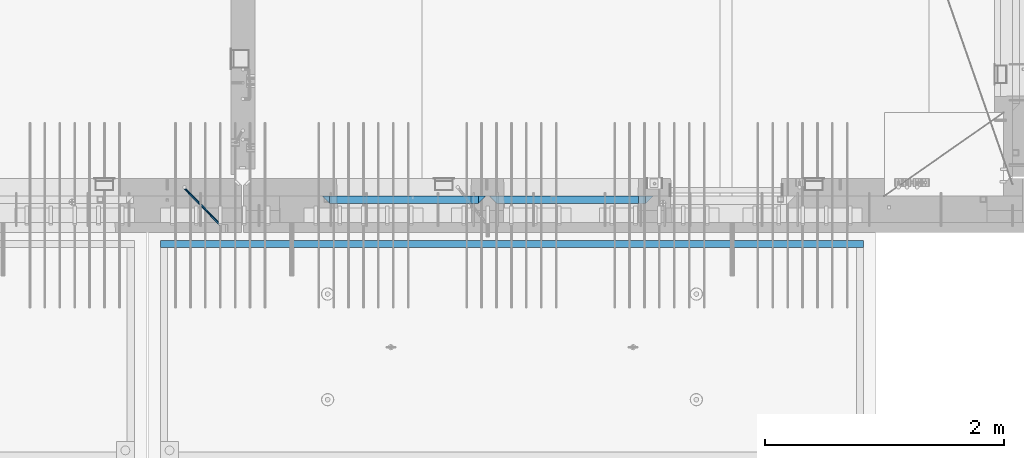
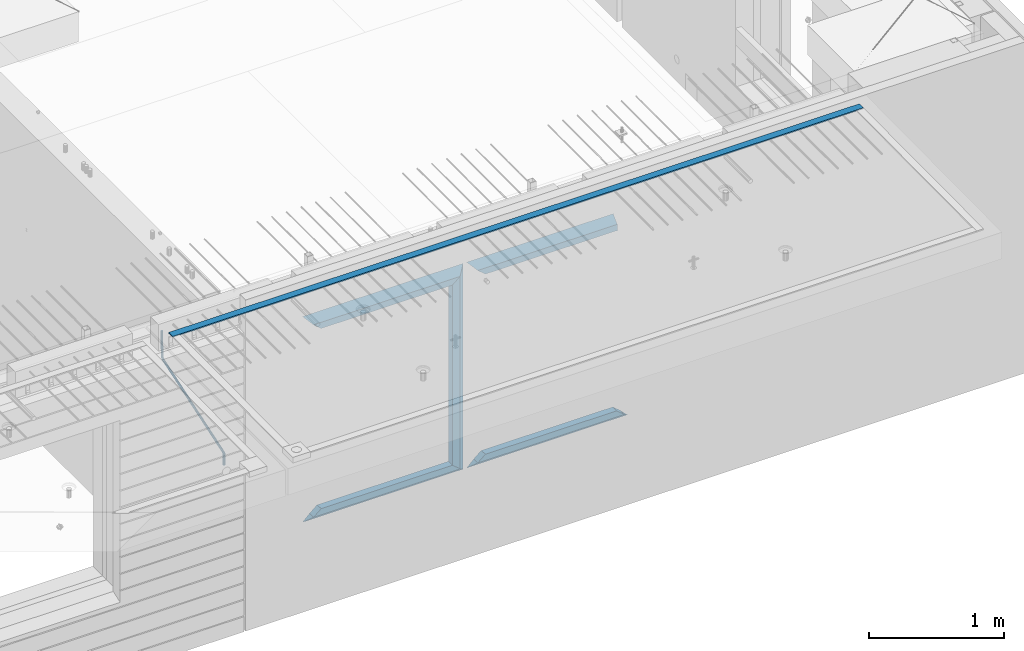
# One storey, part 98 of 350: 12 beams, 3 elements without a shape of their own.
"""IFC2X3 building model written with IfcOpenShell, lengths in millimetres."""

from ifc_helpers import new_model, si_unit, frame, origin_with_axes, place, context, subcontext, project, spatial, faceted_brep, material, type_object, element, aggregate, save


model = new_model("IFC2X3")

# Units and contexts
model_context = context("Model", 3, precision=1e-05, world=origin_with_axes())
body_context = subcontext(model_context, "Body", "Model", "MODEL_VIEW")
ifc_project = project(units=[si_unit("LENGTHUNIT", "METRE", prefix="MILLI"), si_unit("AREAUNIT", "SQUARE_METRE"), si_unit("VOLUMEUNIT", "CUBIC_METRE"), si_unit("MASSUNIT", "GRAM", prefix="KILO"), si_unit("TIMEUNIT", "SECOND"), si_unit("PLANEANGLEUNIT", "RADIAN"), si_unit("SOLIDANGLEUNIT", "STERADIAN"), si_unit("THERMODYNAMICTEMPERATUREUNIT", "DEGREE_CELSIUS"), si_unit("LUMINOUSINTENSITYUNIT", "LUMEN")], contexts=[model_context])

# Site, building, storey
site_placement = place(None, origin_with_axes())
site = spatial("IfcSite", under=ifc_project, at=site_placement, CompositionType="ELEMENT")
building_placement = place(site_placement, origin_with_axes())
building = spatial("IfcBuilding", under=site, at=building_placement, CompositionType="ELEMENT")
storey_placement = place(building_placement, origin_with_axes())
storey = spatial("IfcBuildingStorey", under=building, at=storey_placement, Name="2", CompositionType="ELEMENT", Elevation=0.0)

# Assembly, beam
assembly_1_placement = place(storey_placement, origin_with_axes())
assembly_1 = element("IfcElementAssembly", 1, at=assembly_1_placement, inside=storey, AssemblyPlace="NOTDEFINED", PredefinedType="REINFORCEMENT_UNIT")
ifc_material_1 = material()
beam_type_1 = type_object("IfcBeamType", Name="D20", PredefinedType="NOTDEFINED")
beam_1_placement = place(assembly_1_placement, frame((28120.0219996506, 7924.99999995055, 87407.5), z_axis=(-0.000415599999849952, -0.999999913638316, 0.0), x_axis=(-0.00018169900008877, 0.0, -0.999999983492737)))
beam_1 = element("IfcBeam", 2, at=beam_1_placement, type_object=beam_type_1, material=ifc_material_1, Name="JM20", ObjectType="D20", context=body_context, shape_type="Brep", body=[
    faceted_brep([(-0.00060564729210455, -9.99999998165731, 0.0), (-0.000428079845733009, -7.07106779890455, -7.07106781186667), (119.575515501536, -7.07830994756296, -7.07106481604933), (119.575337932896, -10.0072421307195, -3.43332612828817e-06), (0.0, 0.0, -10.0), (119.575943836026, -0.00724214867295814, -9.99999700418266), (0.00042843479604926, 7.07106779888636, -7.07106781186303), (119.57637202373, 7.06382565022977, -7.07106481604933), (0.00060564729210455, 9.99999998166459, 3.63797880709171e-12), (119.576549238118, 9.99275783300072, 2.99581552098971e-06), (0.000428079845733009, 7.07106779890819, 7.07106781186667), (119.576371669405, 7.06382565024978, 7.07107080768037), (0.0, 0.0, 10.0), (119.57594333493, -0.00724214864203532, 10.0000029958155), (-0.000428434810601175, -7.07106779888272, 7.07106781186667), (119.575515147211, -7.07830994754295, 7.07107080768037), (123.007838984922, -7.07805953274146, -6.96781646693489), (122.583416564885, -10.0070226667376, 0.0904895847234002), (123.182432386879, -0.00697902713727672, -9.89150957511447), (123.004922326727, 7.0640757898218, -6.96792996825661), (122.579291790258, 9.99297690664025, 0.09032907062101), (122.154869373029, 7.06401377197108, 7.14863512328429), (121.980275971029, -0.00706673364766175, 10.0723282314621), (122.157786031181, -7.0781215506031, 7.1487486246051), (232.991069545737, -7.0553235628031, -0.344989315878593), (232.56664713427, -9.98428669916029, 6.71331673826626), (233.165662947809, 0.0157569427356066, -3.26868242414184), (232.988152887861, 7.08681175970924, -0.345102817348561), (232.562522351524, 10.0157128766077, 6.71315622151724), (232.138099934426, 7.08674974201131, 13.7714622742333), (231.963506532353, 0.0156692364653281, 16.6951553824965), (232.141016592301, -7.05538558050466, 13.7715757757042), (248.076986635424, -5.5847993905918, 1.85861828010275), (247.029610002806, -8.57448599522468, 8.8259290931519), (244.875536996158, -5.81406760439131, 15.6317136598209), (242.87659436863, 1.07944012639928, 18.2892356835691), (242.20373560088, 8.06791386077748, 15.2417548051744), (243.251112233527, 11.0576004654249, 8.27444399212709), (245.405185240103, 8.29718207458427, 1.4686594254481), (247.40412786763, 1.40367434377549, -1.1888625983047), (260.566830172145, 5.47100196453175, 3.19131575132906), (262.023113325369, -1.27539050352425, 6.49949830426976), (256.884070167318, 11.8442033958454, 5.28851055269934), (253.132144174728, 14.110878827727, 11.5625744366826), (251.508879555811, 10.9432405336265, 18.3382458712176), (252.965162709021, 4.19684806558143, 21.6464284241465), (256.647922713819, -2.17635336575768, 19.5492336227662), (260.399848700399, -4.44302879667157, 13.2751697364092), (1011.72756124764, 322.959435794994, 337.688425673249), (1010.10429662876, 319.79179750097, 344.464097107826), (1010.27127809466, 329.705828263024, 334.380243120345), (1006.58851809015, 336.079029694381, 336.477437921801), (1002.83659209782, 338.345705126318, 342.751501805859), (1001.21332747894, 335.178066832297, 349.527173240437), (1002.66961063194, 328.431674364263, 352.835355793341), (1006.35237063644, 322.058472932906, 350.738160991886), (1012.15285167976, 323.143366902459, 337.876301685487), (1011.27592458235, 320.298507294498, 344.981674676291), (1011.36533099508, 330.178988123705, 334.863551186057), (1009.37468146477, 337.283999466545, 337.708251560521), (1007.34699858574, 340.296381647149, 344.744015910405), (1006.47007148832, 337.45152203918, 351.849388901209), (1007.25759217299, 330.415900817941, 354.862139400639), (1009.24824170329, 323.310889475106, 352.017439026175), (1012.6528516715, 323.14345775195, 337.876301647731), (1012.65336908352, 320.298757574768, 344.981674572278), (1012.65157305435, 330.179221832586, 334.863551088932), (1012.65028222866, 337.284594639881, 337.708251313175), (1012.64973534261, 340.297345149043, 344.744015509988), (1012.65025275464, 337.452644971851, 351.849388434534), (1012.65153137178, 330.416880891225, 354.862138993334), (1012.65282219746, 323.311508083931, 352.017438769089), (1117.44132683994, 323.162497711652, 337.876293734989), (1117.44184425197, 320.31779753447, 344.981666659536), (1117.44004822278, 330.198261792288, 334.863543176189), (1117.43875739709, 337.303634599582, 337.708243400433), (1117.43821051104, 340.316385108745, 344.744007597245), (1117.43872792307, 337.471684931556, 351.849380521792), (1117.44000654022, 330.435920850927, 354.862131080592), (1117.44129736591, 323.330548043632, 352.017430856347)], [[[0, 1, 2, 3]], [[1, 4, 5, 2]], [[4, 6, 7, 5]], [[6, 8, 9, 7]], [[8, 10, 11, 9]], [[10, 12, 13, 11]], [[12, 14, 15, 13]], [[14, 0, 3, 15]], [[14, 12, 10, 8, 6, 4, 1, 0]], [[3, 2, 16, 17]], [[2, 5, 18, 16]], [[5, 7, 19, 18]], [[7, 9, 20, 19]], [[9, 11, 21, 20]], [[11, 13, 22, 21]], [[13, 15, 23, 22]], [[15, 3, 17, 23]], [[17, 16, 24, 25]], [[16, 18, 26, 24]], [[18, 19, 27, 26]], [[19, 20, 28, 27]], [[20, 21, 29, 28]], [[21, 22, 30, 29]], [[22, 23, 31, 30]], [[23, 17, 25, 31]], [[25, 24, 32, 33]], [[31, 25, 33, 34]], [[30, 31, 34, 35]], [[29, 30, 35, 36]], [[28, 29, 36, 37]], [[27, 28, 37, 38]], [[26, 27, 38, 39]], [[24, 26, 39, 32]], [[39, 40, 41, 32]], [[38, 42, 40, 39]], [[37, 43, 42, 38]], [[36, 44, 43, 37]], [[35, 45, 44, 36]], [[34, 46, 45, 35]], [[33, 47, 46, 34]], [[32, 41, 47, 33]], [[47, 41, 48, 49]], [[41, 40, 50, 48]], [[40, 42, 51, 50]], [[42, 43, 52, 51]], [[43, 44, 53, 52]], [[44, 45, 54, 53]], [[45, 46, 55, 54]], [[46, 47, 49, 55]], [[49, 48, 56, 57]], [[48, 50, 58, 56]], [[50, 51, 59, 58]], [[51, 52, 60, 59]], [[52, 53, 61, 60]], [[53, 54, 62, 61]], [[54, 55, 63, 62]], [[55, 49, 57, 63]], [[57, 56, 64, 65]], [[56, 58, 66, 64]], [[58, 59, 67, 66]], [[59, 60, 68, 67]], [[60, 61, 69, 68]], [[61, 62, 70, 69]], [[62, 63, 71, 70]], [[63, 57, 65, 71]], [[65, 64, 72, 73]], [[64, 66, 74, 72]], [[66, 67, 75, 74]], [[67, 68, 76, 75]], [[68, 69, 77, 76]], [[69, 70, 78, 77]], [[70, 71, 79, 78]], [[71, 65, 73, 79]], [[74, 75, 76, 77, 78, 79, 73, 72]]]),
])
aggregate(assembly_1, [beam_1])

assembly_2_placement = place(storey_placement, origin_with_axes())
assembly_2 = element("IfcElementAssembly", 3, at=assembly_2_placement, inside=storey, AssemblyPlace="NOTDEFINED", PredefinedType="REINFORCEMENT_UNIT")
ifc_material_2 = material(Name="CONCRETE/Concrete_Undefined")
beam_type_2 = type_object("IfcBeamType", PredefinedType="NOTDEFINED")
beam_2_placement = place(assembly_2_placement, frame((33810.0034098489, 7449.93184428067, 87725.278844281), z_axis=(6.5298999993069e-05, -1.00000033840378e-09, 0.99999999786802), x_axis=(-0.999999997792817, 1.22639999974798e-05, 6.52989999859729e-05)))
beam_2 = element("IfcBeam", 4, at=beam_2_placement, type_object=beam_type_2, material=ifc_material_2, context=body_context, shape_type="Brep", body=[
    faceted_brep([(2.5465851649642e-11, 29.9999999999982, -4.99999999998545), (-2.91038304567337e-11, 29.9999999999982, 5.0), (5890.06001043805, 29.9999999999991, 5.00000000001455), (5890.06001043806, 30.0, -4.99999999998545), (-2.5465851649642e-11, -30.0000000000018, 5.0), (5890.06001043806, -30.0, 5.00000000001455), (2.72848410531878e-11, -30.0000000000018, -4.99999999998545), (5890.06001043806, -30.0, -5.0)], [[[0, 1, 2, 3]], [[1, 4, 5, 2]], [[4, 6, 7, 5]], [[6, 0, 3, 7]], [[5, 7, 3, 2]], [[6, 4, 1, 0]]]),
])
aggregate(assembly_2, [beam_2])

# Assembly, beams
assembly_3_placement = place(storey_placement, origin_with_axes())
assembly_3 = element("IfcElementAssembly", 5, at=assembly_3_placement, inside=storey, AssemblyPlace="NOTDEFINED", PredefinedType="REINFORCEMENT_UNIT")
ifc_material_3 = material(Name="CONCRETE/C35/45")
beam_type_3 = type_object("IfcBeamType", PredefinedType="NOTDEFINED")
beam_3_placement = place(assembly_3_placement, frame((30674.9996552717, 7820.0, 87145.0), z_axis=(0.0, 0.0, -1.0), x_axis=(1.0, 0.0, 0.0)))
beam_3 = element("IfcBeam", 6, at=beam_3_placement, type_object=beam_type_3, material=ifc_material_3, Name="SK", context=body_context, shape_type="Brep", body=[
    faceted_brep([(1249.99847412109, -30.0, 30.0), (1249.99847412109, -29.999999998452, -30.0), (1249.99847412109, 30.0, 30.0), (60.0000000000073, -30.0, 30.0), (0.0, -30.0, -30.0), (60.0000000000073, 30.0, 30.0)], [[[0, 1, 2]], [[1, 0, 3, 4]], [[2, 1, 4, 5]], [[0, 2, 5, 3]], [[5, 4, 3]]]),
])
beam_4_placement = place(assembly_3_placement, frame((30734.9996552717, 7820.0, 87085.0), z_axis=(0.0, 0.0, -1.0), x_axis=(1.0, 0.0, 0.0)))
beam_4 = element("IfcBeam", 7, at=beam_4_placement, type_object=beam_type_3, material=ifc_material_3, Name="SK", context=body_context, shape_type="Brep", body=[
    faceted_brep([(1189.99847412109, -30.0, 30.0), (1189.99847412109, -30.0, -30.0), (1189.99847412109, 30.0, -30.0), (1189.99847412109, 30.0, 30.0), (1184.32279844542, 30.0, 30.0), (1185.94442006704, -30.0, 30.0), (1184.32279844542, 29.999999998452, 25.6756756756804), (1185.94442006696, -29.999999998452, 24.0540540541406), (65.6741497967687, 29.999999998452, 25.6756756756804), (64.0525281752307, -29.999999998452, 24.0540540541406), (65.6741497967687, 29.999999998452, 26.2921283848846), (64.0525281752307, -29.999999998452, 24.9021669953072), (0.0, -30.0, -30.0), (0.0, 30.0, -30.0)], [[[0, 1, 2, 3]], [[0, 3, 4, 5]], [[5, 4, 6, 7]], [[7, 6, 8, 9]], [[9, 8, 10, 11]], [[1, 0, 5, 7, 9, 11, 12]], [[2, 1, 12, 13]], [[8, 6, 4, 3, 2, 13, 10]], [[10, 13, 12, 11]]]),
])
ifc_material_4 = material(Name="CONCRETE/C30/37")
beam_5_placement = place(assembly_3_placement, frame((32044.9981293928, 7820.0, 85350.0), z_axis=(0.0, 0.0, 1.0), x_axis=(-1.0, 3.00000001838171e-08, 0.0)))
beam_5 = element("IfcBeam", 8, at=beam_5_placement, type_object=beam_type_3, material=ifc_material_4, Name="SK", context=body_context, shape_type="Brep", body=[
    faceted_brep([(1309.99847412109, 30.0, 30.0), (1309.99847412109, -30.0, 30.0), (1369.99847412109, -30.0, -30.0), (0.0, -30.0, -30.0), (60.0000000000073, 30.0, 30.0), (60.0000000000073, -30.0, 30.0)], [[[0, 1, 2]], [[3, 4, 0, 2]], [[4, 5, 1, 0]], [[5, 3, 2, 1]], [[4, 3, 5]]]),
])
beam_6_placement = place(assembly_3_placement, frame((31984.9981293928, 7820.0, 85410.0), z_axis=(0.0, 0.0, 1.0), x_axis=(-1.0, 3.00000001838171e-08, 0.0)))
beam_6 = element("IfcBeam", 9, at=beam_6_placement, type_object=beam_type_3, material=ifc_material_3, Name="SK", context=body_context, shape_type="Brep", body=[
    faceted_brep([(1185.94594588314, -29.9999988381387, 24.0540541168593), (1184.32432432432, 29.9999988381387, 25.6756756756804), (65.6756756756768, 30.0, 25.6756756756804), (64.0540540540533, -30.0, 24.0540540540533), (1185.94594594586, -29.999999998452, 24.9021669952926), (1184.32432432433, 29.999999998452, 26.2921283848846), (1249.99847412109, -29.999999998452, -30.0), (1249.99847412109, 29.999999998452, -30.0), (0.0, -30.0, -30.0), (0.0, 30.0, -30.0), (65.6756756756768, 30.0, 26.293436281092), (64.0540540540533, -30.0, 24.9034748914419)], [[[0, 1, 2, 3]], [[1, 0, 4, 5]], [[5, 4, 6, 7]], [[8, 9, 7, 6]], [[2, 1, 5, 7, 9, 10]], [[3, 2, 10, 11]], [[6, 4, 0, 3, 11, 8]], [[8, 11, 10, 9]]]),
])
beam_7_placement = place(assembly_3_placement, frame((29275.0000367414, 7820.0, 87145.0), z_axis=(0.0, 0.0, -1.0), x_axis=(1.0, 0.0, 0.0)))
beam_7 = element("IfcBeam", 10, at=beam_7_placement, type_object=beam_type_3, material=ifc_material_4, Name="SK", context=body_context, shape_type="Brep", body=[
    faceted_brep([(60.0000000000073, 30.0, 30.0), (0.0, -30.0, -30.0), (60.0000000000073, -30.0, 30.0), (1370.00038146973, -30.0, -30.0), (1310.0003814697, -30.0, 30.0), (1310.0003814697, 30.0, 30.0)], [[[0, 1, 2]], [[2, 1, 3, 4]], [[0, 2, 4, 5]], [[1, 0, 5, 3]], [[3, 5, 4]]]),
])
beam_8_placement = place(assembly_3_placement, frame((29335.0000367414, 7820.0, 87085.0), z_axis=(0.0, 0.0, -1.0), x_axis=(1.0, 0.0, 0.0)))
beam_8 = element("IfcBeam", 11, at=beam_8_placement, type_object=beam_type_3, material=ifc_material_3, Name="SK", context=body_context, shape_type="Brep", body=[
    faceted_brep([(1185.94632735287, -29.9999988381387, 24.0540541168593), (1184.32470579405, 29.9999988381387, 25.6756756756804), (65.6760571454033, 29.9999988381387, 25.6756756756804), (64.0544355865859, -29.9999988381387, 24.0540541168593), (65.6760571454033, 29.9999988381387, 26.2937632551475), (64.0544355865859, -29.9999988381387, 24.9038019193104), (0.0, 30.0, -30.0), (0.0, -30.0, -30.0), (1250.00038146973, -29.9999988381387, -30.0), (1185.94632735287, -29.9999988381387, 24.9034749452549), (1184.32470579405, 29.9999988381387, 26.2934362810629), (1250.00038146973, 29.9999988381387, -30.0)], [[[0, 1, 2, 3]], [[3, 2, 4, 5]], [[5, 4, 6, 7]], [[0, 3, 5, 7, 8, 9]], [[1, 0, 9, 10]], [[6, 4, 2, 1, 10, 11]], [[7, 6, 11, 8]], [[8, 11, 10, 9]]]),
])
beam_9_placement = place(assembly_3_placement, frame((30615.0004182112, 7820.0, 87175.0), z_axis=(-1.0, 3.00000001838171e-08, 0.0), x_axis=(0.0, 0.0, -1.0)))
beam_9 = element("IfcBeam", 12, at=beam_9_placement, type_object=beam_type_3, material=ifc_material_4, Name="SK", context=body_context, shape_type="Brep", body=[
    faceted_brep([(60.0000000000073, 30.0, 30.0), (0.0, -30.0, -30.0), (60.0000000000073, -30.0, 30.0), (1855.0, -30.0, -30.0), (1795.00000000001, -30.0, 30.0), (1795.00000000001, 30.0, 30.0)], [[[0, 1, 2]], [[3, 4, 2, 1]], [[4, 5, 0, 2]], [[5, 3, 1, 0]], [[4, 3, 5]]]),
])
beam_10_placement = place(assembly_3_placement, frame((30645.0004182112, 7820.0, 85350.0), z_axis=(0.0, 0.0, 1.0), x_axis=(-1.0, 3.00000001838171e-08, 0.0)))
beam_10 = element("IfcBeam", 13, at=beam_10_placement, type_object=beam_type_3, material=ifc_material_4, Name="SK", context=body_context, shape_type="Brep", body=[
    faceted_brep([(1370.00038146973, -30.0, -30.0), (1310.0003814697, 30.0, 30.0), (1310.0003814697, -30.0, 30.0), (0.0, -30.0, -30.0), (60.0000000000073, 30.0, 30.0), (60.0000000000073, -30.0, 30.0)], [[[0, 1, 2]], [[3, 4, 1, 0]], [[4, 5, 2, 1]], [[5, 3, 0, 2]], [[4, 3, 5]]]),
])
beam_11_placement = place(assembly_3_placement, frame((30585.0004182112, 7820.0, 85410.0), z_axis=(0.0, 0.0, 1.0), x_axis=(-1.0, 3.00000001838171e-08, 0.0)))
beam_11 = element("IfcBeam", 14, at=beam_11_placement, type_object=beam_type_3, material=ifc_material_3, Name="SK", context=body_context, shape_type="Brep", body=[
    faceted_brep([(1185.94594588314, -29.9999988381387, 24.0540541168593), (1184.32432432432, 29.9999988381387, 25.6756756756804), (65.6756756756768, 30.0, 25.6756756756804), (64.0540540540533, -30.0, 24.0540540540533), (1185.94594588314, -29.9999988381387, 24.9038019193104), (1184.32432432432, 29.9999988381387, 26.2937632551329), (1250.00038146973, -29.9999988381387, -30.0), (1250.00038146973, 29.9999988381387, -30.0), (0.0, -30.0, -30.0), (0.0, 30.0, -30.0), (65.6756756756768, 30.0, 26.293436281092), (64.0540540540533, -30.0, 24.9034748914419)], [[[0, 1, 2, 3]], [[1, 0, 4, 5]], [[4, 6, 7, 5]], [[8, 9, 7, 6]], [[2, 1, 5, 7, 9, 10]], [[3, 2, 10, 11]], [[6, 4, 0, 3, 11, 8]], [[8, 11, 10, 9]]]),
])
beam_type_4 = type_object("IfcBeamType", PredefinedType="NOTDEFINED")
beam_12_placement = place(assembly_3_placement, frame((30550.0004182112, 7820.0, 87115.0), z_axis=(-1.0, 3.00000001838171e-08, 0.0), x_axis=(0.0, 0.0, -1.0)))
beam_12 = element("IfcBeam", 15, at=beam_12_placement, type_object=beam_type_4, material=ifc_material_3, Name="SK", context=body_context, shape_type="Brep", body=[
    faceted_brep([(0.0, -30.0, -35.0), (54.9034748914273, -30.0, 29.0540540540533), (56.2934362811066, 30.0, 30.6756756756768), (0.0, 30.0, -35.0), (1735.0, -30.0, -35.0), (1680.09652510857, -30.0, 29.0540540540533), (1678.70656371891, 30.0, 30.6756756756768), (1735.0, 30.0, -35.0)], [[[0, 1, 2, 3]], [[1, 0, 4, 5]], [[2, 1, 5, 6]], [[3, 2, 6, 7]], [[7, 4, 0, 3]], [[4, 7, 6, 5]]]),
])
aggregate(assembly_3, [beam_3, beam_4, beam_5, beam_6, beam_7, beam_8, beam_9, beam_12, beam_10, beam_11])

save(model, "model.ifc")
